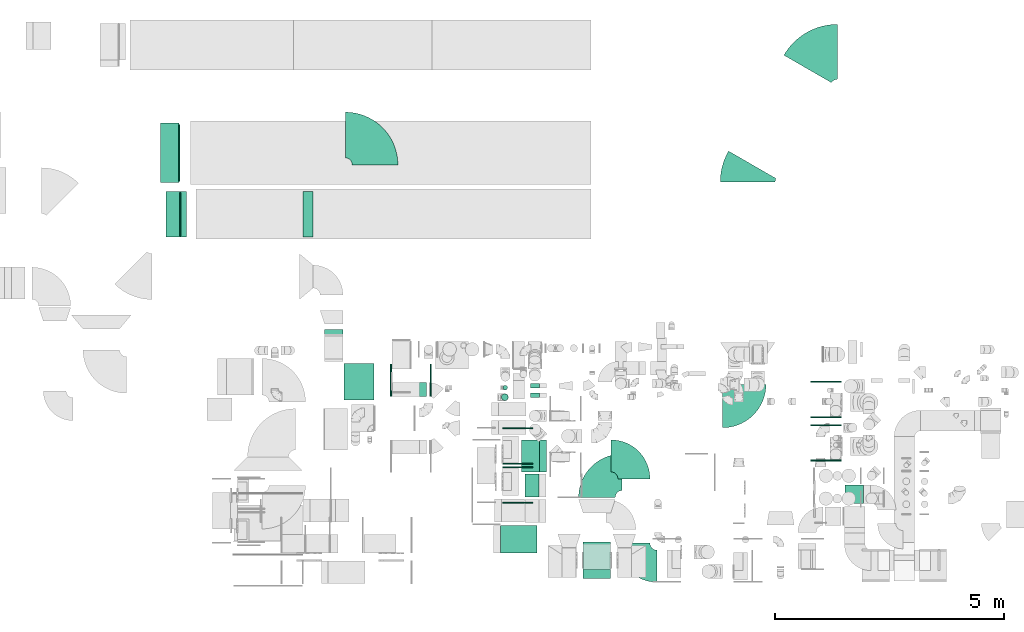
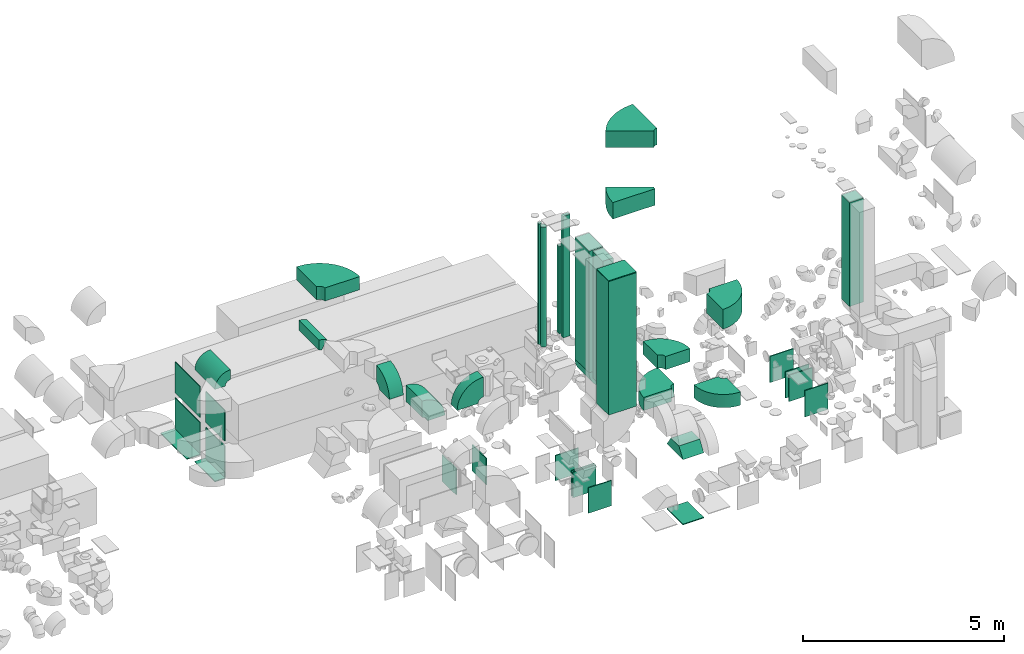
# One storey, part 4 of 59: 32 flow fittings, 8 flow segments.
"""IFC2X3 building model written with IfcOpenShell, lengths in millimetres."""

import ifcopenshell
import ifcopenshell.guid

model = None  # the IFC model being written
_history = None  # IfcOwnerHistory: only IFC2X3 demands one
_inside = {}  # id of a spatial element -> (the spatial element, [elements in it])
_under = {}  # id of a project, library or spatial element -> (it, [spatial elements below it])
_declared = {}  # id of a project -> (the project, [libraries it declares])
_typed = {}  # id of a type object -> (the type object, [elements of that type])
_made_of = {}  # id of a material, layer set ... -> (it, [elements and type objects made of it])


def new_model(schema):
    """Start an empty IFC model of exactly this schema.

    Asked for "IFC4X3", IfcOpenShell would pick the latest addendum, in which some entities
    have other attributes; the version numbers below select the first issue.
    IFC2X3 requires an IfcOwnerHistory on every rooted entity: one is made here for all.
    """
    global model, _history
    if schema == "IFC4X3":
        model = ifcopenshell.file(schema_version=(4, 3, 0, 0))
    else:
        model = ifcopenshell.file(schema=schema)
    _inside.clear()
    _under.clear()
    _declared.clear()
    _typed.clear()
    _made_of.clear()
    _history = None
    if model.schema == "IFC2X3":
        org = make("IfcOrganization", Name="unknown")
        user = make(
            "IfcPersonAndOrganization",
            ThePerson=make("IfcPerson", FamilyName="unknown"),
            TheOrganization=org,
        )
        app = make(
            "IfcApplication",
            ApplicationDeveloper=org,
            Version="unknown",
            ApplicationFullName="unknown",
            ApplicationIdentifier="unknown",
        )
        _history = make(
            "IfcOwnerHistory",
            OwningUser=user,
            OwningApplication=app,
            ChangeAction="ADDED",
            CreationDate=0,
        )
    return model


def make(cls, **values):
    """One entity of the class cls with the attributes given. An attribute that is None is left unset."""
    return model.create_entity(
        cls, **{name: value for name, value in values.items() if value is not None}
    )


def entity(cls, *values):
    """Any entity or typed value of the class cls, its attributes in the order of the schema. None: left unset."""
    e = model.create_entity(cls)
    for i, value in enumerate(values):
        if value is not None:
            e[i] = value
    return e


def rooted(cls, **values):
    """An entity with a GlobalId (a new one), such as an element, a storey or a relation."""
    return make(cls, GlobalId=ifcopenshell.guid.new(), OwnerHistory=_history, **values)


def si_unit(unit_type, name, prefix=None):
    """IfcSIUnit, for example si_unit("LENGTHUNIT", "METRE", prefix="MILLI")."""
    return make("IfcSIUnit", UnitType=unit_type, Prefix=prefix, Name=name)


def converted_unit(unit_type, name, factor, base, dimensions=None, offset=None):
    """IfcConversionBasedUnit, such as the inch: factor (a typed value) times the base unit."""
    return make(
        "IfcConversionBasedUnit"
        if offset is None
        else "IfcConversionBasedUnitWithOffset",
        ConversionOffset=offset,
        Dimensions=None
        if dimensions is None
        else entity("IfcDimensionalExponents", *dimensions),
        UnitType=unit_type,
        Name=name,
        ConversionFactor=make(
            "IfcMeasureWithUnit", ValueComponent=factor, UnitComponent=base
        ),
    )


def derived_unit(unit_type, elements):
    """IfcDerivedUnit: a product of units, each with its exponent."""
    return make(
        "IfcDerivedUnit",
        Elements=[
            make("IfcDerivedUnitElement", Unit=unit, Exponent=power)
            for unit, power in elements
        ],
        UnitType=unit_type,
    )


def assignment(units):
    """IfcUnitAssignment: the units of a project."""
    return None if units is None else make("IfcUnitAssignment", Units=units)


def point(xyz):
    """IfcCartesianPoint."""
    return None if xyz is None else make("IfcCartesianPoint", Coordinates=xyz)


def direction(xyz):
    """IfcDirection."""
    return None if xyz is None else make("IfcDirection", DirectionRatios=xyz)


def frame(location, z_axis=None, x_axis=None):
    """IfcAxis2Placement3D, a coordinate frame: its origin and axes. An axis left out is left unset."""
    return make(
        "IfcAxis2Placement3D",
        Location=point(location),
        Axis=direction(z_axis),
        RefDirection=direction(x_axis),
    )


def frame_2d(location, x_axis=None):
    """IfcAxis2Placement2D, a coordinate frame in the plane: its origin and x axis."""
    return make(
        "IfcAxis2Placement2D", Location=point(location), RefDirection=direction(x_axis)
    )


def origin():
    """The frame at (0, 0, 0) with its axes left unset."""
    return frame((0.0, 0.0, 0.0))


def origin_2d_with_axis():
    """The frame at (0, 0) in the plane with the x axis (1, 0) written out."""
    return frame_2d((0.0, 0.0), x_axis=(1.0, 0.0))


def place(relative_to, where):
    """IfcLocalPlacement: puts the frame where relative to a parent placement (None: the world)."""
    return make(
        "IfcLocalPlacement", PlacementRelTo=relative_to, RelativePlacement=where
    )


def context(
    kind, dimensions, precision=None, world=None, true_north=None, identifier=None
):
    """IfcGeometricRepresentationContext, for example the 3D "Model" context."""
    return make(
        "IfcGeometricRepresentationContext",
        ContextIdentifier=identifier,
        ContextType=kind,
        CoordinateSpaceDimension=dimensions,
        Precision=precision,
        WorldCoordinateSystem=world,
        TrueNorth=true_north,
    )


def subcontext(parent, identifier, kind, view, scale=None):
    """IfcGeometricRepresentationSubContext, for example "Body" below "Model"."""
    return make(
        "IfcGeometricRepresentationSubContext",
        ContextIdentifier=identifier,
        ContextType=kind,
        ParentContext=parent,
        TargetScale=scale,
        TargetView=view,
    )


def project(units=None, contexts=None):
    """IfcProject with its units and contexts."""
    return rooted(
        "IfcProject",
        Name="project",
        RepresentationContexts=contexts,
        UnitsInContext=assignment(units),
    )


def spatial(cls, under=None, at=None, **own):
    """A site, building, storey or space (cls), placed at a placement, below another one or the project."""
    s = rooted(cls, ObjectPlacement=at, **own)
    if under is not None:
        _under.setdefault(under.id(), (under, []))[1].append(s)
    return s


def polyline(points):
    """IfcPolyline through the points."""
    return make("IfcPolyline", Points=[point(p) for p in points])


def circle_curve(where, radius):
    """IfcCircle in the frame where."""
    return make("IfcCircle", Position=where, Radius=radius)


def parameter(value):
    """IfcParameterValue: where a trimmed curve begins or ends, as a parameter of its basis curve."""
    return model.create_entity("IfcParameterValue", value)


def trimmed(basis, trim1, trim2, sense, master):
    """IfcTrimmedCurve: the piece of a basis curve between two trims."""
    return make(
        "IfcTrimmedCurve",
        BasisCurve=basis,
        Trim1=trim1,
        Trim2=trim2,
        SenseAgreement=sense,
        MasterRepresentation=master,
    )


def segment(curve, same_sense, transition):
    """IfcCompositeCurveSegment."""
    return make(
        "IfcCompositeCurveSegment",
        Transition=transition,
        SameSense=same_sense,
        ParentCurve=curve,
    )


def composite_curve(segments, self_intersect=None):
    """IfcCompositeCurve: segments joined end to end."""
    return make("IfcCompositeCurve", Segments=segments, SelfIntersect=self_intersect)


def profile(cls, at=None, kind="AREA", **sizes):
    """A parametric profile (cls). Its sizes go by their IFC names, for example OverallWidth=200.0."""
    return make(cls, ProfileType=kind, Position=at, **sizes)


def rectangle(**sizes):
    """IfcRectangleProfileDef."""
    return profile("IfcRectangleProfileDef", **sizes)


def circle(**sizes):
    """IfcCircleProfileDef."""
    return profile("IfcCircleProfileDef", **sizes)


def outline(outer, holes=None, kind="AREA"):
    """IfcArbitraryClosedProfileDef: a profile drawn as a closed curve; with holes, ...WithVoids."""
    if holes is None:
        return make("IfcArbitraryClosedProfileDef", ProfileType=kind, OuterCurve=outer)
    return make(
        "IfcArbitraryProfileDefWithVoids",
        ProfileType=kind,
        OuterCurve=outer,
        InnerCurves=holes,
    )


def extrude(swept, where, along, depth):
    """IfcExtrudedAreaSolid: the profile swept, set in the frame where, extruded along a direction by depth."""
    return make(
        "IfcExtrudedAreaSolid",
        SweptArea=swept,
        Position=where,
        ExtrudedDirection=direction(along),
        Depth=depth,
    )


def shape(context_of_items, identifier, shape_type, items):
    """IfcShapeRepresentation: the items that make up one representation, for example the "Body"."""
    return make(
        "IfcShapeRepresentation",
        ContextOfItems=context_of_items,
        RepresentationIdentifier=identifier,
        RepresentationType=shape_type,
        Items=items,
    )


def source(mapping_origin, context_of_items, identifier, shape_type, items):
    """IfcRepresentationMap: a shape defined once, which mapped items show again and again."""
    return make(
        "IfcRepresentationMap",
        MappingOrigin=mapping_origin,
        MappedRepresentation=shape(context_of_items, identifier, shape_type, items),
    )


def transform(
    local_origin,
    x_axis=None,
    y_axis=None,
    z_axis=None,
    scale=None,
    scale2=None,
    scale3=None,
    uniform=True,
):
    """IfcCartesianTransformationOperator3D, or its non-uniform kind. x_axis, y_axis, z_axis: its Axis1, 2, 3."""
    if uniform:
        return make(
            "IfcCartesianTransformationOperator3D",
            Axis1=direction(x_axis),
            Axis2=direction(y_axis),
            LocalOrigin=point(local_origin),
            Scale=scale,
            Axis3=direction(z_axis),
        )
    return make(
        "IfcCartesianTransformationOperator3DnonUniform",
        Axis1=direction(x_axis),
        Axis2=direction(y_axis),
        LocalOrigin=point(local_origin),
        Scale=scale,
        Axis3=direction(z_axis),
        Scale2=scale2,
        Scale3=scale3,
    )


def mapped(mapping_source, mapping_target):
    """IfcMappedItem: shows the shape of a source again, moved by a transform."""
    return make(
        "IfcMappedItem", MappingSource=mapping_source, MappingTarget=mapping_target
    )


def material(Name=None, Category=None):
    """IfcMaterial."""
    return make("IfcMaterial", Name=Name, Category=Category)


def made_of(thing, what):
    """Note that an element or type object is made of a material, layer set ...; save() writes the relation."""
    if what is not None:
        _made_of.setdefault(what.id(), (what, []))[1].append(thing)
    return thing


def type_object(cls, material=None, **own):
    """A type object (cls), such as IfcWallType, which elements share."""
    return made_of(rooted(cls, **own), material)


def type_shapes(of_type, sources):
    """Give a type object the sources (RepresentationMaps) that its elements show as mapped items."""
    of_type.RepresentationMaps = sources


def element(
    cls,
    number,
    at=None,
    inside=None,
    cuts=None,
    type_object=None,
    material=None,
    context=None,
    identifier="Body",
    shape_type=None,
    held_by="IfcProductDefinitionShape",
    body=None,
    shapes=None,
    **own,
):
    """One element of the class cls, such as IfcWall. Its Tag is "e" and its number.

    at: its placement. inside: the storey or other place that contains it. cuts: it is an
    opening in that element (IfcRelVoidsElement). A single representation is given by context,
    identifier, shape_type and body (its items); several are given by shapes. held_by: the class
    of the entity that holds the representations. save() writes the other relations.
    """
    e = rooted(cls, Tag="e%d" % number, ObjectPlacement=at, **own)
    if body is not None:
        shapes = [shape(context, identifier, shape_type, body)]
    if shapes is not None:
        e.Representation = make(held_by, Representations=shapes)
    if inside is not None:
        _inside.setdefault(inside.id(), (inside, []))[1].append(e)
    if cuts is not None:
        rooted(
            "IfcRelVoidsElement", RelatingBuildingElement=cuts, RelatedOpeningElement=e
        )
    if type_object is not None:
        _typed.setdefault(type_object.id(), (type_object, []))[1].append(e)
    return made_of(e, material)


def aggregate(whole, parts):
    """IfcRelAggregates: a whole, such as a stair, and the parts it consists of."""
    return rooted("IfcRelAggregates", RelatingObject=whole, RelatedObjects=parts)


def save(model, path):
    """Write the relations noted so far, then the file.

    IfcRelAggregates (storeys below a building ...), IfcRelContainedInSpatialStructure (elements
    in a storey), IfcRelDefinesByType, IfcRelAssociatesMaterial and IfcRelDeclares: one each for
    every whole, place, type object, material and project.
    """
    for whole, parts in _under.values():
        aggregate(whole, parts)
    for where, things in _inside.values():
        rooted(
            "IfcRelContainedInSpatialStructure",
            RelatedElements=things,
            RelatingStructure=where,
        )
    for kind, things in _typed.values():
        rooted("IfcRelDefinesByType", RelatedObjects=things, RelatingType=kind)
    for what, things in _made_of.values():
        rooted("IfcRelAssociatesMaterial", RelatedObjects=things, RelatingMaterial=what)
    for by, libraries in _declared.values():
        rooted("IfcRelDeclares", RelatingContext=by, RelatedDefinitions=libraries)
    model.write(path)


model = new_model("IFC2X3")

# Units and contexts
model_context = context("Model", 3, precision=0.01, world=origin(), true_north=direction((6.12303176911189e-17, 1.0)))
body_context = subcontext(model_context, "Body", "Model", "MODEL_VIEW")
ifc_project = project(units=[si_unit("LENGTHUNIT", "METRE", prefix="MILLI"), si_unit("AREAUNIT", "SQUARE_METRE"), si_unit("VOLUMEUNIT", "CUBIC_METRE"), converted_unit("PLANEANGLEUNIT", "DEGREE", entity("IfcRatioMeasure", 0.0174532925199433), si_unit("PLANEANGLEUNIT", "RADIAN"), dimensions=[0, 0, 0, 0, 0, 0, 0]), si_unit("MASSUNIT", "GRAM", prefix="KILO"), derived_unit("MASSDENSITYUNIT", [(si_unit("MASSUNIT", "GRAM", prefix="KILO"), 1), (si_unit("LENGTHUNIT", "METRE"), -3)]), derived_unit("MOMENTOFINERTIAUNIT", [(si_unit("LENGTHUNIT", "METRE"), 4)]), si_unit("TIMEUNIT", "SECOND"), si_unit("FREQUENCYUNIT", "HERTZ"), si_unit("THERMODYNAMICTEMPERATUREUNIT", "DEGREE_CELSIUS"), derived_unit("THERMALTRANSMITTANCEUNIT", [(si_unit("MASSUNIT", "GRAM", prefix="KILO"), 1), (si_unit("THERMODYNAMICTEMPERATUREUNIT", "KELVIN"), -1), (si_unit("TIMEUNIT", "SECOND"), -3)]), derived_unit("VOLUMETRICFLOWRATEUNIT", [(si_unit("LENGTHUNIT", "METRE"), 3), (si_unit("TIMEUNIT", "SECOND"), -1)]), derived_unit("MASSFLOWRATEUNIT", [(si_unit("MASSUNIT", "GRAM", prefix="KILO"), 1), (si_unit("TIMEUNIT", "SECOND"), -1)]), derived_unit("ROTATIONALFREQUENCYUNIT", [(si_unit("TIMEUNIT", "SECOND"), -1)]), si_unit("ELECTRICCURRENTUNIT", "AMPERE"), si_unit("ELECTRICVOLTAGEUNIT", "VOLT"), si_unit("POWERUNIT", "WATT"), si_unit("FORCEUNIT", "NEWTON", prefix="KILO"), si_unit("ILLUMINANCEUNIT", "LUX"), si_unit("LUMINOUSFLUXUNIT", "LUMEN"), si_unit("LUMINOUSINTENSITYUNIT", "CANDELA"), derived_unit("USERDEFINED", [(si_unit("MASSUNIT", "GRAM", prefix="KILO"), -1), (si_unit("LENGTHUNIT", "METRE"), -2), (si_unit("TIMEUNIT", "SECOND"), 3), (si_unit("LUMINOUSFLUXUNIT", "LUMEN"), 1)]), derived_unit("LINEARVELOCITYUNIT", [(si_unit("LENGTHUNIT", "METRE"), 1), (si_unit("TIMEUNIT", "SECOND"), -1)]), si_unit("PRESSUREUNIT", "PASCAL"), derived_unit("USERDEFINED", [(si_unit("LENGTHUNIT", "METRE"), -2), (si_unit("MASSUNIT", "GRAM", prefix="KILO"), 1), (si_unit("TIMEUNIT", "SECOND"), -2)]), derived_unit("LINEARFORCEUNIT", [(si_unit("MASSUNIT", "GRAM", prefix="KILO"), 1), (si_unit("LENGTHUNIT", "METRE"), 1), (si_unit("TIMEUNIT", "SECOND"), -2), (si_unit("LENGTHUNIT", "METRE"), -1)]), derived_unit("PLANARFORCEUNIT", [(si_unit("MASSUNIT", "GRAM", prefix="KILO"), 1), (si_unit("LENGTHUNIT", "METRE"), 1), (si_unit("TIMEUNIT", "SECOND"), -2), (si_unit("LENGTHUNIT", "METRE"), -2)])], contexts=[model_context])

# Site, building, storey
site_placement = place(None, origin())
site = spatial("IfcSite", under=ifc_project, at=site_placement, CompositionType="ELEMENT")
building_placement = place(site_placement, origin())
building = spatial("IfcBuilding", under=site, at=building_placement, CompositionType="ELEMENT")
storey_placement = place(building_placement, frame((0.0, 0.0, 28200.0)))
storey = spatial("IfcBuildingStorey", under=building, at=storey_placement, CompositionType="ELEMENT", Elevation=28200.0)

# Flow segments
duct_segment_type_1 = type_object("IfcDuctSegmentType", PredefinedType="NOTDEFINED")
flow_segment_1_placement = place(storey_placement, frame((48267.97, 8549.6, 3850.0)))
element("IfcFlowSegment", 1, at=flow_segment_1_placement, inside=storey, type_object=duct_segment_type_1, context=body_context, shape_type="SweptSolid", body=[
    extrude(rectangle(XDim=799.999999999991, YDim=600.0, at=origin_2d_with_axis()), frame((400.0, 300.0, 0.0), z_axis=(0.0, 0.0, 1.0), x_axis=(-1.0, 0.0, 0.0)), (0.0, 0.0, 1.0), 4050.00000000001),
])
flow_segment_2_placement = place(storey_placement, frame((48805.39, 9773.84, 3750.0)))
element("IfcFlowSegment", 2, at=flow_segment_2_placement, inside=storey, type_object=duct_segment_type_1, context=body_context, shape_type="SweptSolid", body=[
    extrude(rectangle(XDim=300.000000000001, YDim=500.000000000001, at=origin_2d_with_axis()), frame((150.0, 250.0, 0.0)), (0.0, 0.0, 1.0), 3836.99997500064),
])
flow_segment_3_placement = place(storey_placement, frame((48723.28, 10318.92, 3900.0)))
element("IfcFlowSegment", 3, at=flow_segment_3_placement, inside=storey, type_object=duct_segment_type_1, context=body_context, shape_type="SweptSolid", body=[
    extrude(rectangle(XDim=399.999999999996, YDim=699.999999999999, at=origin_2d_with_axis()), frame((200.0, 350.0, 0.0)), (0.0, 0.0, 1.0), 3687.00000000063),
])
flow_segment_4_placement = place(storey_placement, frame((48923.0, 12149.48, 3900.0)))
element("IfcFlowSegment", 4, at=flow_segment_4_placement, inside=storey, type_object=duct_segment_type_1, context=body_context, shape_type="SweptSolid", body=[
    extrude(rectangle(XDim=99.9999999999989, YDim=199.999999999998, at=origin_2d_with_axis()), frame((100.0, 50.0, 0.0), z_axis=(0.0, 0.0, 1.0), x_axis=(0.0, 1.0, 0.0)), (0.0, 0.0, 1.0), 2649.999975),
])
flow_segment_5_placement = place(storey_placement, frame((48923.0, 11949.48, 3900.0)))
element("IfcFlowSegment", 5, at=flow_segment_5_placement, inside=storey, type_object=duct_segment_type_1, context=body_context, shape_type="SweptSolid", body=[
    extrude(rectangle(XDim=200.000000000007, YDim=100.000000000001, at=origin_2d_with_axis()), frame((100.0, 50.0, 0.0), z_axis=(0.0, 0.0, 1.0), x_axis=(-1.0, 0.0, 0.0)), (0.0, 0.0, 1.0), 3687.00000000063),
])
flow_segment_6_placement = place(storey_placement, frame((55800.5, 9633.0, 3850.0)))
element("IfcFlowSegment", 6, at=flow_segment_6_placement, inside=storey, type_object=duct_segment_type_1, context=body_context, shape_type="SweptSolid", body=[
    extrude(rectangle(XDim=399.999999999996, YDim=400.0, at=origin_2d_with_axis()), frame((200.0, 200.0, 0.0)), (0.0, 0.0, 1.0), 3150.00000000001),
])
duct_segment_type_2 = type_object("IfcDuctSegmentType", PredefinedType="NOTDEFINED")
flow_segment_7_placement = place(storey_placement, frame((48284.45, 11877.18, 3870.0)))
element("IfcFlowSegment", 7, at=flow_segment_7_placement, inside=storey, type_object=duct_segment_type_2, context=body_context, shape_type="SweptSolid", body=[
    extrude(circle(Radius=75.0, at=origin_2d_with_axis()), frame((76.6, 76.6, 0.0), z_axis=(0.0, 0.0, 1.0), x_axis=(0.0, -1.0, 0.0)), (0.0, 0.0, 1.0), 3631.19767404034),
])
flow_segment_8_placement = place(storey_placement, frame((48318.51, 12111.15, 3803.42)))
element("IfcFlowSegment", 8, at=flow_segment_8_placement, inside=storey, type_object=duct_segment_type_2, context=body_context, shape_type="SweptSolid", body=[
    extrude(circle(Radius=50.0, at=origin_2d_with_axis()), frame((51.6, 51.6, 0.0), z_axis=(0.0, 0.0, 1.0), x_axis=(0.0, -1.0, 0.0)), (0.0, 0.0, 1.0), 3660.00000000001),
])

# Flow fittings
ifc_material = material()
duct_fitting_type_1 = type_object("IfcDuctFittingType", PredefinedType="NOTDEFINED", material=ifc_material)
shared_shape_1 = source(origin(), body_context, "Body", "SweptSolid", [
    extrude(rectangle(XDim=24.9999999999999, YDim=700.0, at=origin_2d_with_axis()), frame((12.5, 0.0, -400.0)), (0.0, 0.0, 1.0), 800.0),
])
type_shapes(duct_fitting_type_1, [shared_shape_1])
flow_fitting_1_placement = place(storey_placement, frame((46724.94, 12320.6, 600.0)))
element("IfcFlowFitting", 9, at=flow_fitting_1_placement, inside=storey, type_object=duct_fitting_type_1, material=ifc_material, context=body_context, shape_type="MappedRepresentation", body=[
    mapped(shared_shape_1, transform((0.0, 0.0, 0.0), scale=1.0)),
])
flow_fitting_2_placement = place(storey_placement, frame((45884.94, 12320.6, 600.0), z_axis=(0.0, 0.0, 1.0), x_axis=(-1.0, 0.0, 0.0)))
element("IfcFlowFitting", 10, at=flow_fitting_2_placement, inside=storey, type_object=duct_fitting_type_1, material=ifc_material, context=body_context, shape_type="MappedRepresentation", body=[
    mapped(shared_shape_1, transform((0.0, 0.0, 0.0), scale=1.0)),
])
duct_fitting_type_2 = type_object("IfcDuctFittingType", PredefinedType="NOTDEFINED", material=ifc_material)
shared_shape_2 = source(origin(), body_context, "Body", "SweptSolid", [
    extrude(rectangle(XDim=24.9999999999999, YDim=600.0, at=origin_2d_with_axis()), frame((12.5, 0.0, -400.0)), (0.0, 0.0, 1.0), 800.0),
])
type_shapes(duct_fitting_type_2, [shared_shape_2])
for number, where, z_axis, x_axis in (
    (11, (50373.61, 8390.0, 250.0), (0.0, 1.0, 0.0), (0.0, 0.0, -1.0)),
    (12, (48667.97, 8849.6, 7900.0), (-1.0, 0.0, 0.0), (0.0, 0.0, 1.0)),
):
    element("IfcFlowFitting", number, at=place(storey_placement, frame(where, z_axis=z_axis, x_axis=x_axis)), inside=storey, type_object=duct_fitting_type_2, material=ifc_material, context=body_context, shape_type="MappedRepresentation", body=[
        mapped(shared_shape_2, transform((0.0, 0.0, 0.0), scale=1.0)),
    ])
duct_fitting_type_3 = type_object("IfcDuctFittingType", PredefinedType="NOTDEFINED", material=ifc_material)
shared_shape_3 = source(origin(), body_context, "Body", "SweptSolid", [
    extrude(rectangle(XDim=24.9999999999999, YDim=660.0, at=origin_2d_with_axis()), frame((12.5, 0.0, -385.0)), (0.0, 0.0, 1.0), 770.0),
])
type_shapes(duct_fitting_type_3, [shared_shape_3])
for number, where, z_axis, x_axis in (
    (13, (48640.88, 9659.01, 585.0), (0.0, 0.0, 1.0), (0.0, -1.0, 0.0)),
    (14, (48640.88, 10409.01, 585.0), (0.0, 0.0, 1.0), (0.0, 1.0, 0.0)),
    (15, (48640.88, 10509.01, 585.0), (0.0, 0.0, 1.0), (0.0, -1.0, 0.0)),
    (16, (48640.88, 11259.01, 585.0), (0.0, 0.0, 1.0), (0.0, 1.0, 0.0)),
):
    element("IfcFlowFitting", number, at=place(storey_placement, frame(where, z_axis=z_axis, x_axis=x_axis)), inside=storey, type_object=duct_fitting_type_3, material=ifc_material, context=body_context, shape_type="MappedRepresentation", body=[
        mapped(shared_shape_3, transform((0.0, 0.0, 0.0), scale=1.0)),
    ])
duct_fitting_type_4 = type_object("IfcDuctFittingType", PredefinedType="NOTDEFINED", material=ifc_material)
shared_shape_4 = source(origin(), body_context, "Body", "SweptSolid", [
    extrude(rectangle(XDim=26.0960000000188, YDim=938.0, at=origin_2d_with_axis()), frame((6.95, 0.0, -619.0)), (0.0, 0.0, 1.0), 1238.0),
])
type_shapes(duct_fitting_type_4, [shared_shape_4])
for number, where, z_axis, x_axis in (
    (17, (41233.7, 17294.64, 1785.0), (0.0, -1.0, 0.0), (1.0, 0.0, 0.0)),
    (18, (41233.7, 17294.64, 695.0), (0.0, -1.0, 0.0), (1.0, 0.0, 0.0)),
):
    element("IfcFlowFitting", number, at=place(storey_placement, frame(where, z_axis=z_axis, x_axis=x_axis)), inside=storey, type_object=duct_fitting_type_4, material=ifc_material, context=body_context, shape_type="MappedRepresentation", body=[
        mapped(shared_shape_4, transform((0.0, 0.0, 0.0), scale=1.0)),
    ])
duct_fitting_type_5 = type_object("IfcDuctFittingType", PredefinedType="NOTDEFINED", material=ifc_material)
shared_shape_5 = source(origin(), body_context, "Body", "SweptSolid", [
    extrude(rectangle(XDim=24.9999999999999, YDim=400.0, at=origin_2d_with_axis()), frame((12.5, 0.0, -650.0)), (0.0, 0.0, 1.0), 1300.0),
])
type_shapes(duct_fitting_type_5, [shared_shape_5])
flow_fitting_3_placement = place(storey_placement, frame((41033.7, 17294.64, 220.0), z_axis=(0.0, -1.0, 0.0), x_axis=(0.0, 0.0, -1.0)))
element("IfcFlowFitting", 19, at=flow_fitting_3_placement, inside=storey, type_object=duct_fitting_type_5, material=ifc_material, context=body_context, shape_type="MappedRepresentation", body=[
    mapped(shared_shape_5, transform((0.0, 0.0, 0.0), scale=1.0)),
])
duct_fitting_type_6 = type_object("IfcDuctFittingType", PredefinedType="NOTDEFINED", material=ifc_material)
shared_shape_6 = source(origin(), body_context, "Body", "SweptSolid", [
    extrude(rectangle(XDim=938.0, YDim=26.0960000000087, at=origin_2d_with_axis()), frame((6.95, 0.0, -469.0), z_axis=(0.0, 0.0, 1.0), x_axis=(0.0, -1.0, 0.0)), (0.0, 0.0, 1.0), 938.0),
])
type_shapes(duct_fitting_type_6, [shared_shape_6])
for number, where, z_axis, x_axis in (
    (20, (41253.7, 15954.64, 1785.0), (0.0, -1.0, 0.0), (1.0, 0.0, 0.0)),
    (21, (41253.7, 15954.64, 695.0), (0.0, -1.0, 0.0), (1.0, 0.0, 0.0)),
):
    element("IfcFlowFitting", number, at=place(storey_placement, frame(where, z_axis=z_axis, x_axis=x_axis)), inside=storey, type_object=duct_fitting_type_6, material=ifc_material, context=body_context, shape_type="MappedRepresentation", body=[
        mapped(shared_shape_6, transform((0.0, 0.0, 0.0), scale=1.0)),
    ])
duct_fitting_type_7 = type_object("IfcDuctFittingType", PredefinedType="NOTDEFINED", material=ifc_material)
shared_shape_7 = source(origin(), body_context, "Body", "SweptSolid", [
    extrude(rectangle(XDim=24.9999999999999, YDim=300.0, at=origin_2d_with_axis()), frame((12.5, 0.0, -500.0)), (0.0, 0.0, 1.0), 1000.0),
])
type_shapes(duct_fitting_type_7, [shared_shape_7])
flow_fitting_4_placement = place(storey_placement, frame((41103.7, 15954.64, 220.0), z_axis=(0.0, -1.0, 0.0), x_axis=(0.0, 0.0, -1.0)))
element("IfcFlowFitting", 22, at=flow_fitting_4_placement, inside=storey, type_object=duct_fitting_type_7, material=ifc_material, context=body_context, shape_type="MappedRepresentation", body=[
    mapped(shared_shape_7, transform((0.0, 0.0, 0.0), scale=1.0)),
])
duct_fitting_type_8 = type_object("IfcDuctFittingType", PredefinedType="NOTDEFINED", material=ifc_material)
shared_shape_8 = source(origin(), body_context, "Body", "SweptSolid", [
    extrude(outline(polyline([(-346.69, -249.62), (13.87, -249.62), (235.75, 83.21), (97.07, 416.03), (-346.69, -249.62)])), frame((150.0, -300.0, 0.0), z_axis=(0.0, 1.0, 0.0), x_axis=(0.832050294337805, 0.0, -0.554700196225287)), (0.0, 0.0, 1.0), 600.0),
])
type_shapes(duct_fitting_type_8, [shared_shape_8])
flow_fitting_5_placement = place(storey_placement, frame((50373.61, 8390.0, 2205.0), z_axis=(0.0, 1.0, 0.0), x_axis=(0.0, 0.0, 1.0)))
element("IfcFlowFitting", 23, at=flow_fitting_5_placement, inside=storey, type_object=duct_fitting_type_8, material=ifc_material, context=body_context, shape_type="MappedRepresentation", body=[
    mapped(shared_shape_8, transform((0.0, 0.0, 0.0), scale=1.0)),
])
duct_fitting_type_9 = type_object("IfcDuctFittingType", PredefinedType="NOTDEFINED", material=ifc_material)
shared_shape_9 = source(origin(), body_context, "Body", "SweptSolid", [
    extrude(rectangle(XDim=24.9999999999999, YDim=670.0, at=origin_2d_with_axis()), frame((12.5, 0.0, -400.0)), (0.0, 0.0, 1.0), 800.0),
])
type_shapes(duct_fitting_type_9, [shared_shape_9])
for number, where, z_axis, x_axis in (
    (24, (55385.02, 11530.6, 600.0), (0.0, 0.0, 1.0), (0.0, -1.0, 0.0)),
    (25, (55385.02, 12280.6, 600.0), (0.0, 0.0, 1.0), (0.0, 1.0, 0.0)),
    (26, (55385.02, 10580.6, 600.0), (0.0, 0.0, 1.0), (0.0, -1.0, 0.0)),
):
    element("IfcFlowFitting", number, at=place(storey_placement, frame(where, z_axis=z_axis, x_axis=x_axis)), inside=storey, type_object=duct_fitting_type_9, material=ifc_material, context=body_context, shape_type="MappedRepresentation", body=[
        mapped(shared_shape_9, transform((0.0, 0.0, 0.0), scale=1.0)),
    ])
duct_fitting_type_10 = type_object("IfcDuctFittingType", PredefinedType="NOTDEFINED", material=ifc_material)
shared_shape_10 = source(origin(), body_context, "Body", "SweptSolid", [
    extrude(rectangle(XDim=24.9999999999999, YDim=800.0, at=origin_2d_with_axis()), frame((12.5, 0.0, -335.0)), (0.0, 0.0, 1.0), 670.0),
])
type_shapes(duct_fitting_type_10, [shared_shape_10])
flow_fitting_6_placement = place(storey_placement, frame((55385.02, 11330.6, 600.0), z_axis=(-1.0, 0.0, 0.0), x_axis=(0.0, 1.0, 0.0)))
element("IfcFlowFitting", 27, at=flow_fitting_6_placement, inside=storey, type_object=duct_fitting_type_10, material=ifc_material, context=body_context, shape_type="MappedRepresentation", body=[
    mapped(shared_shape_10, transform((0.0, 0.0, 0.0), scale=1.0)),
])
duct_fitting_type_11 = type_object("IfcDuctFittingType", PredefinedType="NOTDEFINED", material=ifc_material)
shared_shape_11 = source(origin(), body_context, "Body", "SweptSolid", [
    extrude(outline(composite_curve([segment(polyline([(-375.0, -175.0), (25.0, -175.0)]), True, "CONTINUOUS"), segment(trimmed(circle_curve(frame_2d((175.0, -175.0), x_axis=(0.0, 1.0)), 150.0), [parameter(0.0)], [parameter(90.0000000000001)], True, "PARAMETER"), False, "CONTINUOUS"), segment(polyline([(175.0, -25.0), (175.0, 375.0)]), True, "CONTINUOUS"), segment(trimmed(circle_curve(frame_2d((175.0, -175.0), x_axis=(0.0, 1.0)), 550.0), [parameter(0.0)], [parameter(90.0)], True, "PARAMETER"), True, "CONTINUOUS")], self_intersect=False)), frame((-175.0, 175.0, -350.0), z_axis=(0.0, 0.0, 1.0), x_axis=(-1.0, 0.0, 0.0)), (0.0, 0.0, 1.0), 700.0),
])
type_shapes(duct_fitting_type_11, [shared_shape_11])
flow_fitting_7_placement = place(storey_placement, frame((48923.28, 10668.92, 3550.0), z_axis=(0.0, 1.0, 0.0), x_axis=(-1.0, 0.0, 0.0)))
element("IfcFlowFitting", 28, at=flow_fitting_7_placement, inside=storey, type_object=duct_fitting_type_11, material=ifc_material, context=body_context, shape_type="MappedRepresentation", body=[
    mapped(shared_shape_11, transform((0.0, 0.0, 0.0), scale=1.0)),
])
duct_fitting_type_12 = type_object("IfcDuctFittingType", PredefinedType="NOTDEFINED", material=ifc_material)
shared_shape_12 = source(origin(), body_context, "Body", "SweptSolid", [
    extrude(outline(composite_curve([segment(polyline([(-675.0, -275.0), (125.0, -275.0)]), True, "CONTINUOUS"), segment(trimmed(circle_curve(frame_2d((275.0, -275.0), x_axis=(0.0, 1.0)), 150.0), [parameter(0.0)], [parameter(90.0000000000001)], True, "PARAMETER"), False, "CONTINUOUS"), segment(polyline([(275.0, -125.0), (275.0, 675.0)]), True, "CONTINUOUS"), segment(trimmed(circle_curve(frame_2d((275.0, -275.0), x_axis=(0.0, 1.0)), 950.0), [parameter(0.0)], [parameter(90.0000000000001)], True, "PARAMETER"), True, "CONTINUOUS")], self_intersect=False)), frame((-275.0, 275.0, -200.0), z_axis=(0.0, 0.0, 1.0), x_axis=(-1.0, 0.0, 0.0)), (0.0, 0.0, 1.0), 400.0),
])
type_shapes(duct_fitting_type_12, [shared_shape_12])
flow_fitting_8_placement = place(storey_placement, frame((50373.61, 10311.5, 2855.02), z_axis=(0.0, -4.07617517378659e-05, 1.0), x_axis=(-1.0, 0.0, 0.0)))
element("IfcFlowFitting", 29, at=flow_fitting_8_placement, inside=storey, type_object=duct_fitting_type_12, material=ifc_material, context=body_context, shape_type="MappedRepresentation", body=[
    mapped(shared_shape_12, transform((0.0, 0.0, 0.0), scale=1.0)),
])
duct_fitting_type_13 = type_object("IfcDuctFittingType", PredefinedType="NOTDEFINED", material=ifc_material)
shared_shape_13 = source(origin(), body_context, "Body", "SweptSolid", [
    extrude(outline(composite_curve([segment(polyline([(-600.0, -250.0), (100.0, -250.0)]), True, "CONTINUOUS"), segment(trimmed(circle_curve(frame_2d((250.0, -250.0), x_axis=(0.0, 1.0)), 150.0), [parameter(0.0)], [parameter(90.0000000000016)], True, "PARAMETER"), False, "CONTINUOUS"), segment(polyline([(250.0, -100.0), (250.0, 600.0)]), True, "CONTINUOUS"), segment(trimmed(circle_curve(frame_2d((250.0, -250.0), x_axis=(0.0, 1.0)), 850.0), [parameter(0.0)], [parameter(90.0000000000016)], True, "PARAMETER"), True, "CONTINUOUS")], self_intersect=False)), frame((-250.0, 250.0, -200.0), z_axis=(0.0, 0.0, 1.0), x_axis=(-1.0, 0.0, 0.0)), (0.0, 0.0, 1.0), 400.0),
])
type_shapes(duct_fitting_type_13, [shared_shape_13])
for number, where, z_axis, x_axis in (
    (30, (51183.42, 8260.0, 3550.0), (0.0, 0.0, 1.0), (0.0, -1.0, 0.0)),
    (31, (51183.42, 10668.92, 3550.0), (0.0, 0.0, 1.0), (0.0, 1.0, 0.0)),
):
    element("IfcFlowFitting", number, at=place(storey_placement, frame(where, z_axis=z_axis, x_axis=x_axis)), inside=storey, type_object=duct_fitting_type_13, material=ifc_material, context=body_context, shape_type="MappedRepresentation", body=[
        mapped(shared_shape_13, transform((0.0, 0.0, 0.0), scale=1.0)),
    ])
duct_fitting_type_14 = type_object("IfcDuctFittingType", PredefinedType="NOTDEFINED", material=ifc_material)
shared_shape_14 = source(origin(), body_context, "Body", "SweptSolid", [
    extrude(outline(composite_curve([segment(polyline([(-525.0, -225.0), (75.0, -225.0)]), True, "CONTINUOUS"), segment(trimmed(circle_curve(frame_2d((225.0, -225.0), x_axis=(0.0, 1.0)), 150.0), [parameter(0.0)], [parameter(90.0)], True, "PARAMETER"), False, "CONTINUOUS"), segment(polyline([(225.0, -75.0), (225.0, 525.0)]), True, "CONTINUOUS"), segment(trimmed(circle_curve(frame_2d((225.0, -225.0), x_axis=(0.0, 1.0)), 750.0), [parameter(0.0)], [parameter(90.0)], True, "PARAMETER"), True, "CONTINUOUS")], self_intersect=False)), frame((-225.0, 225.0, -150.0), z_axis=(0.0, 0.0, 1.0), x_axis=(-1.0, 0.0, 0.0)), (0.0, 0.0, 1.0), 300.0),
])
type_shapes(duct_fitting_type_14, [shared_shape_14])
flow_fitting_9_placement = place(storey_placement, frame((46195.05, 12120.6, 3200.0), z_axis=(0.0, -1.0, 0.0), x_axis=(-1.0, 0.0, 0.0)))
element("IfcFlowFitting", 32, at=flow_fitting_9_placement, inside=storey, type_object=duct_fitting_type_14, material=ifc_material, context=body_context, shape_type="MappedRepresentation", body=[
    mapped(shared_shape_14, transform((0.0, 0.0, 0.0), scale=1.0)),
])
duct_fitting_type_15 = type_object("IfcDuctFittingType", PredefinedType="NOTDEFINED", material=ifc_material)
shared_shape_15 = source(origin(), body_context, "Body", "SweptSolid", [
    extrude(outline(composite_curve([segment(polyline([(-825.0, -325.0), (175.0, -325.0)]), True, "CONTINUOUS"), segment(trimmed(circle_curve(frame_2d((325.0, -325.0), x_axis=(0.0, 1.0)), 150.0), [parameter(0.0)], [parameter(90.0)], True, "PARAMETER"), False, "CONTINUOUS"), segment(polyline([(325.0, -175.0), (325.0, 825.0)]), True, "CONTINUOUS"), segment(trimmed(circle_curve(frame_2d((325.0, -325.0), x_axis=(0.0, 1.0)), 1150.0), [parameter(0.0)], [parameter(90.0)], True, "PARAMETER"), True, "CONTINUOUS")], self_intersect=False)), frame((-325.0, 325.0, -200.0), z_axis=(0.0, 0.0, 1.0), x_axis=(-1.0, 0.0, 0.0)), (0.0, 0.0, 1.0), 400.0),
])
type_shapes(duct_fitting_type_15, [shared_shape_15])
flow_fitting_10_placement = place(storey_placement, frame((45522.31, 17684.6, 3500.0), z_axis=(0.0, 0.0, 1.0), x_axis=(0.0, 1.0, 0.0)))
element("IfcFlowFitting", 33, at=flow_fitting_10_placement, inside=storey, type_object=duct_fitting_type_15, material=ifc_material, context=body_context, shape_type="MappedRepresentation", body=[
    mapped(shared_shape_15, transform((0.0, 0.0, 0.0), scale=1.0)),
])
duct_fitting_type_16 = type_object("IfcDuctFittingType", PredefinedType="NOTDEFINED", material=ifc_material)
shared_shape_16 = source(origin(), body_context, "Body", "SweptSolid", [
    extrude(outline(composite_curve([segment(polyline([(-450.0, -200.0), (50.0, -200.0)]), True, "CONTINUOUS"), segment(trimmed(circle_curve(frame_2d((200.0, -200.0), x_axis=(0.0, 1.0)), 150.0), [parameter(0.0)], [parameter(90.0000000000001)], True, "PARAMETER"), False, "CONTINUOUS"), segment(polyline([(200.0, -50.0), (200.0, 450.0)]), True, "CONTINUOUS"), segment(trimmed(circle_curve(frame_2d((200.0, -200.0), x_axis=(0.0, 1.0)), 650.0), [parameter(0.0)], [parameter(90.0000000000001)], True, "PARAMETER"), True, "CONTINUOUS")], self_intersect=False)), frame((-200.0, 200.0, -200.0), z_axis=(0.0, 0.0, 1.0), x_axis=(-1.0, 0.0, 0.0)), (0.0, 0.0, 1.0), 400.0),
])
type_shapes(duct_fitting_type_16, [shared_shape_16])
flow_fitting_11_placement = place(storey_placement, frame((44620.31, 13037.27, 3500.0), z_axis=(1.0, 0.0, 0.0), x_axis=(0.0, -1.0, 0.0)))
element("IfcFlowFitting", 34, at=flow_fitting_11_placement, inside=storey, type_object=duct_fitting_type_16, material=ifc_material, context=body_context, shape_type="MappedRepresentation", body=[
    mapped(shared_shape_16, transform((0.0, 0.0, 0.0), scale=1.0)),
])
duct_fitting_type_17 = type_object("IfcDuctFittingType", PredefinedType="NOTDEFINED", material=ifc_material)
shared_shape_17 = source(origin(), body_context, "Body", "SweptSolid", [
    extrude(outline(composite_curve([segment(polyline([(-787.5, -324.76), (412.5, -324.76)]), True, "CONTINUOUS"), segment(trimmed(circle_curve(frame_2d((562.5, -324.76), x_axis=(-0.5, 0.86602540378442)), 150.0), [parameter(0.0)], [parameter(60.0)], True, "PARAMETER"), False, "CONTINUOUS"), segment(polyline([(487.5, -194.86), (-112.5, 844.37)]), True, "CONTINUOUS"), segment(trimmed(circle_curve(frame_2d((562.5, -324.76), x_axis=(-0.5, 0.86602540378442)), 1350.0), [parameter(0.0)], [parameter(60.0)], True, "PARAMETER"), True, "CONTINUOUS")], self_intersect=False)), frame((-108.25, 187.5, -250.0), z_axis=(0.0, 0.0, 1.0), x_axis=(-0.866025403784439, 0.5, 0.0)), (0.0, 0.0, 1.0), 500.0),
])
type_shapes(duct_fitting_type_17, [shared_shape_17])
flow_fitting_12_placement = place(storey_placement, frame((55198.14, 19504.6, 3450.0), z_axis=(0.0, 0.0, 1.0), x_axis=(-1.0, 0.0, 0.0)))
element("IfcFlowFitting", 35, at=flow_fitting_12_placement, inside=storey, type_object=duct_fitting_type_17, material=ifc_material, context=body_context, shape_type="MappedRepresentation", body=[
    mapped(shared_shape_17, transform((0.0, 0.0, 0.0), scale=1.0)),
])
duct_fitting_type_18 = type_object("IfcDuctFittingType", PredefinedType="NOTDEFINED", material=ifc_material)
shared_shape_18 = source(origin(), body_context, "Body", "SweptSolid", [
    extrude(outline(composite_curve([segment(polyline([(-450.0, -200.0), (50.0, -200.0)]), True, "CONTINUOUS"), segment(trimmed(circle_curve(frame_2d((200.0, -200.0), x_axis=(0.0, 1.0)), 150.0), [parameter(0.0)], [parameter(90.0000000000001)], True, "PARAMETER"), False, "CONTINUOUS"), segment(polyline([(200.0, -50.0), (200.0, 450.0)]), True, "CONTINUOUS"), segment(trimmed(circle_curve(frame_2d((200.0, -200.0), x_axis=(0.0, 1.0)), 650.0), [parameter(0.0)], [parameter(90.0000000000001)], True, "PARAMETER"), True, "CONTINUOUS")], self_intersect=False)), frame((-200.0, 200.0, -400.0), z_axis=(0.0, 0.0, 1.0), x_axis=(-1.0, 0.0, 0.0)), (0.0, 0.0, 1.0), 800.0),
])
type_shapes(duct_fitting_type_18, [shared_shape_18])
flow_fitting_13_placement = place(storey_placement, frame((45245.05, 12289.6, 3200.0), z_axis=(0.0, 1.0, 0.0), x_axis=(1.0, 0.0, 0.0)))
element("IfcFlowFitting", 36, at=flow_fitting_13_placement, inside=storey, type_object=duct_fitting_type_18, material=ifc_material, context=body_context, shape_type="MappedRepresentation", body=[
    mapped(shared_shape_18, transform((0.0, 0.0, 0.0), scale=1.0)),
])
duct_fitting_type_19 = type_object("IfcDuctFittingType", PredefinedType="NOTDEFINED", material=ifc_material)
shared_shape_19 = source(origin(), body_context, "Body", "SweptSolid", [
    extrude(outline(composite_curve([segment(polyline([(-300.0, -150.0), (0.0, -150.0)]), True, "CONTINUOUS"), segment(trimmed(circle_curve(frame_2d((150.0, -150.0), x_axis=(0.0, 1.0)), 150.0), [parameter(0.0)], [parameter(90.0)], True, "PARAMETER"), False, "CONTINUOUS"), segment(polyline([(150.0, 0.0), (150.0, 300.0)]), True, "CONTINUOUS"), segment(trimmed(circle_curve(frame_2d((150.0, -150.0), x_axis=(0.0, 1.0)), 450.0), [parameter(0.0)], [parameter(90.0000000000001)], True, "PARAMETER"), True, "CONTINUOUS")], self_intersect=False)), frame((-150.0, 150.0, -500.0), z_axis=(0.0, 0.0, 1.0), x_axis=(-1.0, 0.0, 0.0)), (0.0, 0.0, 1.0), 1000.0),
])
type_shapes(duct_fitting_type_19, [shared_shape_19])
flow_fitting_14_placement = place(storey_placement, frame((41103.7, 15954.64, 3300.0), z_axis=(0.0, 1.0, 0.0), x_axis=(0.0, 0.0, 1.0)))
element("IfcFlowFitting", 37, at=flow_fitting_14_placement, inside=storey, type_object=duct_fitting_type_19, material=ifc_material, context=body_context, shape_type="MappedRepresentation", body=[
    mapped(shared_shape_19, transform((0.0, 0.0, 0.0), scale=1.0)),
])
duct_fitting_type_20 = type_object("IfcDuctFittingType", PredefinedType="NOTDEFINED", material=ifc_material)
shared_shape_20 = source(origin(), body_context, "Body", "SweptSolid", [
    extrude(outline(composite_curve([segment(polyline([(-170.1, -75.0), (129.9, -75.0)]), True, "CONTINUOUS"), segment(trimmed(circle_curve(frame_2d((279.9, -75.0), x_axis=(-0.866025410712655, 0.499999987999976)), 150.0), [parameter(0.0)], [parameter(29.9999992060848)], True, "PARAMETER"), False, "CONTINUOUS"), segment(polyline([(150.0, 0.0), (-109.81, 150.0)]), True, "CONTINUOUS"), segment(trimmed(circle_curve(frame_2d((279.9, -75.0), x_axis=(-0.866025410712655, 0.499999987999976)), 450.0), [parameter(0.0)], [parameter(29.9999992060848)], True, "PARAMETER"), True, "CONTINUOUS")], self_intersect=False)), frame((-5.38, 20.1, -500.0), z_axis=(0.0, 0.0, 1.0), x_axis=(-0.499999987999976, 0.866025410712655, 0.0)), (0.0, 0.0, 1.0), 1000.0),
])
type_shapes(duct_fitting_type_20, [shared_shape_20])
flow_fitting_15_placement = place(storey_placement, frame((44025.3, 15954.64, 3300.0), z_axis=(0.0, 1.0, 0.0), x_axis=(1.0, 0.0, 0.0)))
element("IfcFlowFitting", 38, at=flow_fitting_15_placement, inside=storey, type_object=duct_fitting_type_20, material=ifc_material, context=body_context, shape_type="MappedRepresentation", body=[
    mapped(shared_shape_20, transform((0.0, 0.0, 0.0), scale=1.0)),
])
duct_fitting_type_21 = type_object("IfcDuctFittingType", PredefinedType="NOTDEFINED", material=ifc_material)
shared_shape_21 = source(origin(), body_context, "Body", "SweptSolid", [
    extrude(outline(composite_curve([segment(polyline([(-675.0, -275.0), (125.0, -275.0)]), True, "CONTINUOUS"), segment(trimmed(circle_curve(frame_2d((275.0, -275.0), x_axis=(0.0, 1.0)), 150.0), [parameter(0.0)], [parameter(90.0)], True, "PARAMETER"), False, "CONTINUOUS"), segment(polyline([(275.0, -125.0), (275.0, 675.0)]), True, "CONTINUOUS"), segment(trimmed(circle_curve(frame_2d((275.0, -275.0), x_axis=(0.0, 1.0)), 950.0), [parameter(0.0)], [parameter(89.9999999999999)], True, "PARAMETER"), True, "CONTINUOUS")], self_intersect=False)), frame((-275.0, 275.0, -300.0), z_axis=(0.0, 0.0, 1.0), x_axis=(-1.0, 0.0, 0.0)), (0.0, 0.0, 1.0), 600.0),
])
type_shapes(duct_fitting_type_21, [shared_shape_21])
flow_fitting_16_placement = place(storey_placement, frame((53671.11, 11685.34, 3400.0)))
element("IfcFlowFitting", 39, at=flow_fitting_16_placement, inside=storey, type_object=duct_fitting_type_21, material=ifc_material, context=body_context, shape_type="MappedRepresentation", body=[
    mapped(shared_shape_21, transform((0.0, 0.0, 0.0), scale=1.0)),
])
duct_fitting_type_22 = type_object("IfcDuctFittingType", PredefinedType="NOTDEFINED", material=ifc_material)
shared_shape_22 = source(origin(), body_context, "Body", "SweptSolid", [
    extrude(outline(composite_curve([segment(polyline([(-650.24, -187.5), (549.76, -187.5)]), True, "CONTINUOUS"), segment(trimmed(circle_curve(frame_2d((699.76, -187.5), x_axis=(-0.866025403784441, 0.5)), 150.0), [parameter(0.0)], [parameter(30.0)], True, "PARAMETER"), False, "CONTINUOUS"), segment(polyline([(569.86, -112.5), (-469.37, 487.5)]), True, "CONTINUOUS"), segment(trimmed(circle_curve(frame_2d((699.76, -187.5), x_axis=(-0.866025403784441, 0.5)), 1350.0), [parameter(0.0)], [parameter(30.0)], True, "PARAMETER"), True, "CONTINUOUS")], self_intersect=False)), frame((-13.46, 50.24, -250.0), z_axis=(0.0, 0.0, 1.0), x_axis=(-0.5, 0.866025403784439, 0.0)), (0.0, 0.0, 1.0), 500.0),
])
type_shapes(duct_fitting_type_22, [shared_shape_22])
flow_fitting_17_placement = place(storey_placement, frame((53671.11, 16859.71, 3450.0), z_axis=(0.0, 0.0, 1.0), x_axis=(-0.5, -0.866025403784439, 0.0)))
element("IfcFlowFitting", 40, at=flow_fitting_17_placement, inside=storey, type_object=duct_fitting_type_22, material=ifc_material, context=body_context, shape_type="MappedRepresentation", body=[
    mapped(shared_shape_22, transform((0.0, 0.0, 0.0), scale=1.0)),
])

save(model, "model.ifc")
